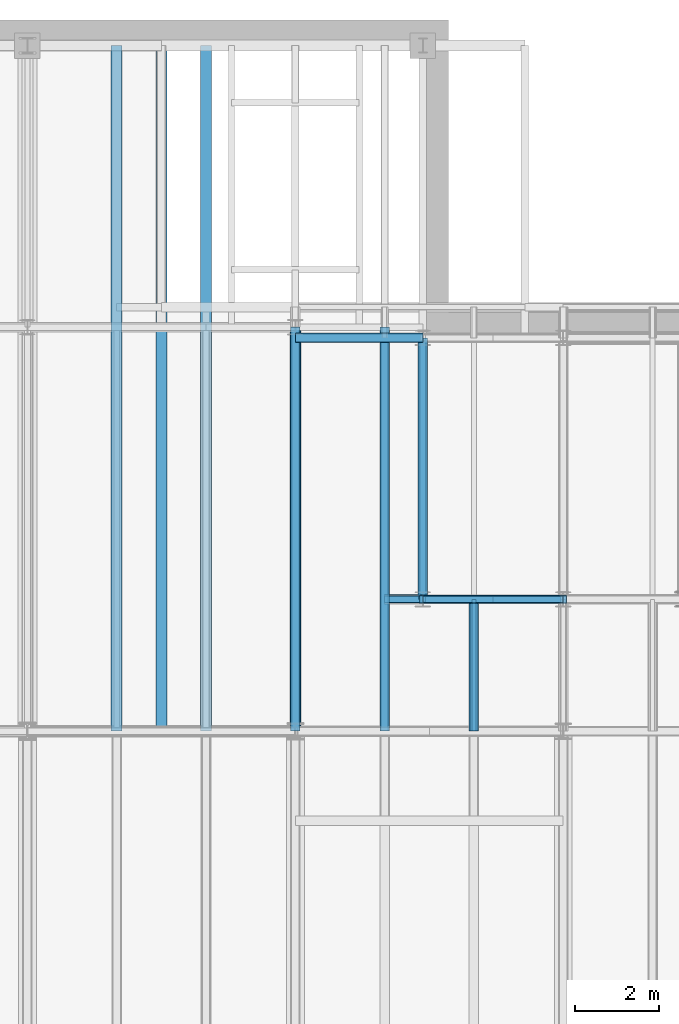
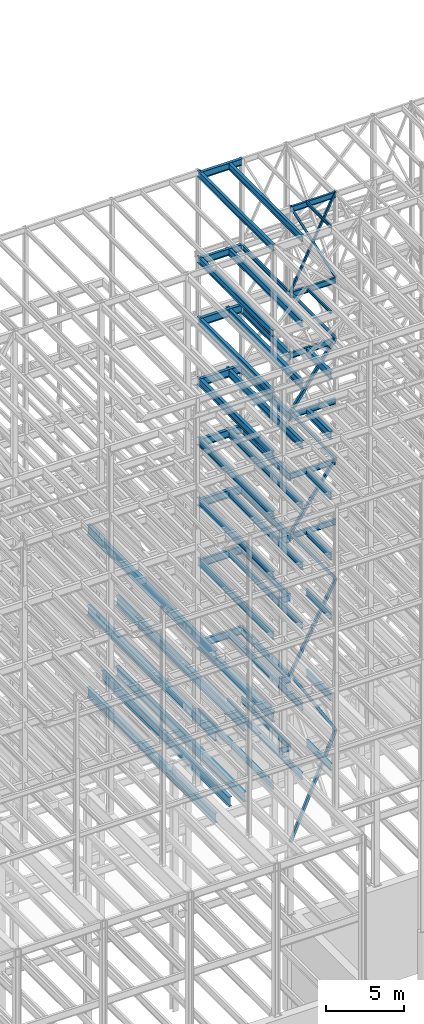
# One storey, part 133 of 150: 69 beams.
"""IFC2X3 building model written with IfcOpenShell, lengths in millimetres."""

from ifc_helpers import new_model, si_unit, frame, origin_with_axes, origin_2d_with_axis, place, context, subcontext, project, spatial, hollow_rectangle, i_section, extrude, material, type_object, element, save


model = new_model("IFC2X3")

# Units and contexts
model_context = context("Model", 3, precision=1e-05, world=origin_with_axes())
body_context = subcontext(model_context, "Body", "Model", "MODEL_VIEW")
ifc_project = project(units=[si_unit("LENGTHUNIT", "METRE", prefix="MILLI"), si_unit("AREAUNIT", "SQUARE_METRE"), si_unit("VOLUMEUNIT", "CUBIC_METRE"), si_unit("MASSUNIT", "GRAM", prefix="KILO"), si_unit("TIMEUNIT", "SECOND"), si_unit("PLANEANGLEUNIT", "RADIAN"), si_unit("SOLIDANGLEUNIT", "STERADIAN"), si_unit("THERMODYNAMICTEMPERATUREUNIT", "DEGREE_CELSIUS"), si_unit("LUMINOUSINTENSITYUNIT", "LUMEN")], contexts=[model_context])

# Site, building, storey
site_placement = place(None, origin_with_axes())
site = spatial("IfcSite", under=ifc_project, at=site_placement, CompositionType="ELEMENT")
building_placement = place(site_placement, origin_with_axes())
building = spatial("IfcBuilding", under=site, at=building_placement, Name="Undefined", CompositionType="ELEMENT")
storey_placement = place(building_placement, origin_with_axes())
storey = spatial("IfcBuildingStorey", under=building, at=storey_placement, Name="Undefined", CompositionType="ELEMENT", Elevation=0.0)

# Beams
ifc_material_1 = material()
beam_type_1 = type_object("IfcBeamType", Name="HSS8X8X3/8", PredefinedType="NOTDEFINED")
beam_1_placement = place(storey_placement, frame((56591.2, 25628.6, 54483.0), z_axis=(0.815507132555285, 0.0, 0.578747023103753), x_axis=(-0.578747023103752, 0.0, 0.815507132555286)))
element("IfcBeam", 1, at=beam_1_placement, inside=storey, type_object=beam_type_1, material=ifc_material_1, Name="BEAM", ObjectType="HSS8X8X3/8", context=body_context, shape_type="SweptSolid", body=[
    extrude(hollow_rectangle(XDim=203.2, YDim=203.2, WallThickness=9.525, InnerFilletRadius=9.5249, OuterFilletRadius=19.0499, at=origin_2d_with_axis()), frame((5793.20491610646, 0.0, -3.21587474211652e-13), z_axis=(-1.0, 0.0, 0.0), x_axis=(0.0, -1.0, 0.0)), (0.0, 0.0, 1.0), 5793.20491610646),
])
beam_2_placement = place(storey_placement, frame((53238.4000344438, 25628.6, 49758.5997408036), z_axis=(-0.815507179752522, 0.0, 0.578746956598553), x_axis=(0.578746956598556, 0.0, 0.81550717975252)))
element("IfcBeam", 2, at=beam_2_placement, inside=storey, type_object=beam_type_1, material=ifc_material_1, Name="BEAM", ObjectType="HSS8X8X3/8", context=body_context, shape_type="SweptSolid", body=[
    extrude(hollow_rectangle(XDim=203.2, YDim=203.2, WallThickness=9.525, InnerFilletRadius=9.5249, OuterFilletRadius=19.0499, at=origin_2d_with_axis()), frame((5793.20510754876, 0.0, 0.0), z_axis=(-1.0, 0.0, 0.0), x_axis=(0.0, -1.0, 0.0)), (0.0, 0.0, 1.0), 5793.20510754876),
])
beam_3_placement = place(storey_placement, frame((56591.2, 25628.6, 45034.2), z_axis=(0.815507132555285, 0.0, 0.578747023103753), x_axis=(-0.578747023103752, 0.0, 0.815507132555286)))
element("IfcBeam", 3, at=beam_3_placement, inside=storey, type_object=beam_type_1, material=ifc_material_1, Name="BEAM", ObjectType="HSS8X8X3/8", context=body_context, shape_type="SweptSolid", body=[
    extrude(hollow_rectangle(XDim=203.2, YDim=203.2, WallThickness=9.525, InnerFilletRadius=9.5249, OuterFilletRadius=19.0499, at=origin_2d_with_axis()), frame((5793.20491610646, 0.0, -3.21587474211652e-13), z_axis=(-1.0, 0.0, 0.0), x_axis=(0.0, -1.0, 0.0)), (0.0, 0.0, 1.0), 5793.20491610647),
])
for number, where, z_axis, x_axis, name in (
    (4, (53238.4, 25628.6, 40309.8), (-0.815507179752522, 0.0, 0.578746956598553), (0.578746956598556, 0.0, 0.81550717975252), "BEAM"),
    (5, (56591.2, 25628.6, 35585.4), (0.815507132555285, 0.0, 0.578747023103753), (-0.578747023103752, 0.0, 0.815507132555286), "BEAM"),
):
    element("IfcBeam", number, at=place(storey_placement, frame(where, z_axis=z_axis, x_axis=x_axis)), inside=storey, type_object=beam_type_1, material=ifc_material_1, Name=name, ObjectType="HSS8X8X3/8", context=body_context, shape_type="SweptSolid", body=[
        extrude(hollow_rectangle(XDim=203.2, YDim=203.2, WallThickness=9.525, InnerFilletRadius=9.5249, OuterFilletRadius=19.0499, at=origin_2d_with_axis()), frame((5793.20491610646, 0.0, -3.21587474211652e-13), z_axis=(-1.0, 0.0, 0.0), x_axis=(0.0, -1.0, 0.0)), (0.0, 0.0, 1.0), 5793.20491610646),
    ])
beam_4_placement = place(storey_placement, frame((53238.4001450863, 25628.6, 29286.1995317612), z_axis=(-0.882746779817135, 0.0, 0.469849042483306), x_axis=(0.469849042483308, 0.0, 0.882746779817133)))
element("IfcBeam", 6, at=beam_4_placement, inside=storey, type_object=beam_type_1, material=ifc_material_1, Name="BEAM", ObjectType="HSS8X8X3/8", context=body_context, shape_type="SweptSolid", body=[
    extrude(hollow_rectangle(XDim=203.2, YDim=203.2, WallThickness=9.525, InnerFilletRadius=9.5249, OuterFilletRadius=19.0499, at=origin_2d_with_axis()), frame((7135.90873022981, 0.0, -3.9612250869624e-13), z_axis=(-1.0, 0.0, 0.0), x_axis=(0.0, -1.0, 0.0)), (0.0, 0.0, 1.0), 7135.90873022981),
])
beam_5_placement = place(storey_placement, frame((56591.2, 25628.6, 23774.4), z_axis=(0.854350562966211, 0.0, 0.519697138302029), x_axis=(-0.519697138302028, 0.0, 0.854350562966211)))
element("IfcBeam", 7, at=beam_5_placement, inside=storey, type_object=beam_type_1, material=ifc_material_1, Name="BEAM", ObjectType="HSS8X8X3/8", context=body_context, shape_type="SweptSolid", body=[
    extrude(hollow_rectangle(XDim=203.2, YDim=203.2, WallThickness=9.525, InnerFilletRadius=9.5249, OuterFilletRadius=19.0499, at=origin_2d_with_axis()), frame((6451.44999825621, 0.0, 0.0), z_axis=(-1.0, 0.0, 0.0), x_axis=(0.0, -1.0, 0.0)), (0.0, 0.0, 1.0), 6451.44999825621),
])
beam_6_placement = place(storey_placement, frame((53238.4, 25628.6, 16154.4), z_axis=(-0.915315032422766, 0.0, 0.402738614266017), x_axis=(0.402738614266017, 0.0, 0.915315032422766)))
element("IfcBeam", 8, at=beam_6_placement, inside=storey, type_object=beam_type_1, material=ifc_material_1, Name="BEAM", ObjectType="HSS8X8X3/8", context=body_context, shape_type="SweptSolid", body=[
    extrude(hollow_rectangle(XDim=203.2, YDim=203.2, WallThickness=9.525, InnerFilletRadius=9.5249, OuterFilletRadius=19.0499, at=origin_2d_with_axis()), frame((8325.00257297258, -7.27595761418343e-12, -4.62130476828891e-13), z_axis=(-1.0, 0.0, 0.0), x_axis=(0.0, -1.0, 0.0)), (0.0, 0.0, 1.0), 8325.00257297258),
])
ifc_material_2 = material(Name="STEEL/A992")
beam_type_2 = type_object("IfcBeamType", Name="W18X35", PredefinedType="NOTDEFINED")
for number, where, z_axis, x_axis, name in (
    (9, (53238.4, 25628.6, 65687.575), (0.0, 0.0, 1.0), (1.0, 0.0, 0.0), "BEAM"),
    (10, (53238.4, 25628.6, 58981.975), (0.0, 0.0, 1.0), (1.0, 0.0, 0.0), "BEAM"),
    (11, (53238.4, 25628.6, 54257.575), (0.0, 0.0, 1.0), (1.0, 0.0, 0.0), "BEAM"),
    (12, (53238.4, 25628.6, 49533.175), (0.0, 0.0, 1.0), (1.0, 0.0, 0.0), "BEAM"),
    (13, (53238.4, 25628.6, 44808.775), (0.0, 0.0, 1.0), (1.0, 0.0, 0.0), "BEAM"),
    (14, (53238.4, 25628.6, 40084.375), (0.0, 0.0, 1.0), (1.0, 0.0, 0.0), "BEAM"),
):
    element("IfcBeam", number, at=place(storey_placement, frame(where, z_axis=z_axis, x_axis=x_axis)), inside=storey, type_object=beam_type_2, material=ifc_material_2, Name=name, ObjectType="W18X35", context=body_context, shape_type="SweptSolid", body=[
        extrude(i_section(OverallWidth=152.4, OverallDepth=450.85, WebThickness=7.9375, FlangeThickness=10.795, FilletRadius=17.78, at=origin_2d_with_axis()), frame((3352.8, 0.0, 0.0), z_axis=(-1.0, 0.0, 0.0), x_axis=(0.0, -1.0, 0.0)), (0.0, 0.0, 1.0), 3352.8),
    ])
beam_7_placement = place(storey_placement, frame((53238.4, 25628.6, 23548.975), z_axis=(0.0, 0.0, 1.0), x_axis=(0.0, 1.0, 0.0)))
element("IfcBeam", 15, at=beam_7_placement, inside=storey, type_object=beam_type_2, material=ifc_material_2, Name="BEAM", ObjectType="W18X35", context=body_context, shape_type="SweptSolid", body=[
    extrude(i_section(OverallWidth=152.4, OverallDepth=450.85, WebThickness=7.9375, FlangeThickness=10.795, FilletRadius=17.78, at=origin_2d_with_axis()), frame((6248.40000000001, 0.0, 0.0), z_axis=(-1.0, 0.0, 0.0), x_axis=(0.0, -1.0, 0.0)), (0.0, 0.0, 1.0), 6248.40000000001),
])
beam_8_placement = place(storey_placement, frame((52324.0, 25628.6, 23548.975), z_axis=(0.0, 0.0, 1.0), x_axis=(1.0, 0.0, 0.0)))
element("IfcBeam", 16, at=beam_8_placement, inside=storey, type_object=beam_type_2, material=ifc_material_2, Name="BEAM", ObjectType="W18X35", context=body_context, shape_type="SweptSolid", body=[
    extrude(i_section(OverallWidth=152.4, OverallDepth=450.85, WebThickness=7.9375, FlangeThickness=10.795, FilletRadius=17.78, at=origin_2d_with_axis()), frame((914.400000000009, 0.0, 0.0), z_axis=(-1.0, 0.0, 0.0), x_axis=(0.0, -1.0, 0.0)), (0.0, 0.0, 1.0), 914.400000000001),
])
beam_type_3 = type_object("IfcBeamType", Name="HSS6X6X1/4", PredefinedType="NOTDEFINED")
for number, where, z_axis, x_axis, name in (
    (17, (56591.2, 25628.6, 59207.4), (0.894427210999918, 0.0, 0.447213555499951), (-0.447213555499953, 0.0, 0.894427210999917), "BEAM"),
    (18, (53238.4, 25628.6, 59207.4), (-0.894427210999918, 0.0, 0.447213555499951), (0.447213555499953, 0.0, 0.894427210999917), "BEAM"),
):
    element("IfcBeam", number, at=place(storey_placement, frame(where, z_axis=z_axis, x_axis=x_axis)), inside=storey, type_object=beam_type_3, material=ifc_material_1, Name=name, ObjectType="HSS6X6X1/4", context=body_context, shape_type="SweptSolid", body=[
        extrude(hollow_rectangle(XDim=152.4, YDim=152.4, WallThickness=6.35, InnerFilletRadius=6.3499, OuterFilletRadius=12.6999, at=origin_2d_with_axis()), frame((7497.08871496129, 0.0, 0.0), z_axis=(-1.0, 0.0, 0.0), x_axis=(0.0, -1.0, 0.0)), (0.0, 0.0, 1.0), 7497.08871496129),
    ])
beam_type_4 = type_object("IfcBeamType", Name="W24X68", PredefinedType="NOTDEFINED")
beam_9_placement = place(storey_placement, frame((53238.4, 25628.6, 54181.375), z_axis=(0.0, 0.0, 1.0), x_axis=(0.0, 1.0, 0.0)))
element("IfcBeam", 19, at=beam_9_placement, inside=storey, type_object=beam_type_4, material=ifc_material_2, Name="BEAM", ObjectType="W24X68", context=body_context, shape_type="SweptSolid", body=[
    extrude(i_section(OverallWidth=227.838, OverallDepth=603.25, WebThickness=11.1125, FlangeThickness=14.859, FilletRadius=23.2409, at=origin_2d_with_axis()), frame((6248.40000000001, 0.0, 0.0), z_axis=(-1.0, 0.0, 0.0), x_axis=(0.0, -1.0, 0.0)), (0.0, 0.0, 1.0), 6248.40000000001),
])
for number, where, z_axis, x_axis, name in (
    (20, (52324.0, 22479.0, 54181.375), (0.0, 0.0, 1.0), (0.0, 1.0, 0.0), "BEAM"),
    (21, (50190.4, 22479.0, 54181.375), (0.0, 0.0, 1.0), (0.0, 1.0, 0.0), "BEAM"),
):
    element("IfcBeam", number, at=place(storey_placement, frame(where, z_axis=z_axis, x_axis=x_axis)), inside=storey, type_object=beam_type_4, material=ifc_material_2, Name=name, ObjectType="W24X68", context=body_context, shape_type="SweptSolid", body=[
        extrude(i_section(OverallWidth=227.838, OverallDepth=603.25, WebThickness=11.1125, FlangeThickness=14.859, FilletRadius=23.2409, at=origin_2d_with_axis()), frame((9652.0, 0.0, 0.0), z_axis=(-1.0, 0.0, 0.0), x_axis=(0.0, -1.0, 0.0)), (0.0, 0.0, 1.0), 9652.0),
    ])
beam_10_placement = place(storey_placement, frame((50190.4, 31877.0, 54181.375), z_axis=(0.0, 0.0, 1.0), x_axis=(1.0, 0.0, 0.0)))
element("IfcBeam", 22, at=beam_10_placement, inside=storey, type_object=beam_type_4, material=ifc_material_2, Name="BEAM", ObjectType="W24X68", context=body_context, shape_type="SweptSolid", body=[
    extrude(i_section(OverallWidth=227.838, OverallDepth=603.25, WebThickness=11.1125, FlangeThickness=14.859, FilletRadius=23.2409, at=origin_2d_with_axis()), frame((3048.0, 0.0, 0.0), z_axis=(-1.0, 0.0, 0.0), x_axis=(0.0, -1.0, 0.0)), (0.0, 0.0, 1.0), 3047.99999999999),
])
beam_11_placement = place(storey_placement, frame((54457.6, 22479.0, 54181.375), z_axis=(0.0, 0.0, 1.0), x_axis=(0.0, 1.0, 0.0)))
element("IfcBeam", 23, at=beam_11_placement, inside=storey, type_object=beam_type_4, material=ifc_material_2, Name="BEAM", ObjectType="W24X68", context=body_context, shape_type="SweptSolid", body=[
    extrude(i_section(OverallWidth=227.838, OverallDepth=603.25, WebThickness=11.1125, FlangeThickness=14.859, FilletRadius=23.2409, at=origin_2d_with_axis()), frame((3149.59999999999, 0.0, 0.0), z_axis=(-1.0, 0.0, 0.0), x_axis=(0.0, -1.0, 0.0)), (0.0, 0.0, 1.0), 3149.6),
])
beam_12_placement = place(storey_placement, frame((53238.4, 25628.6, 49456.975), z_axis=(0.0, 0.0, 1.0), x_axis=(0.0, 1.0, 0.0)))
element("IfcBeam", 24, at=beam_12_placement, inside=storey, type_object=beam_type_4, material=ifc_material_2, Name="BEAM", ObjectType="W24X68", context=body_context, shape_type="SweptSolid", body=[
    extrude(i_section(OverallWidth=227.838, OverallDepth=603.25, WebThickness=11.1125, FlangeThickness=14.859, FilletRadius=23.2409, at=origin_2d_with_axis()), frame((6248.40000000001, 0.0, 0.0), z_axis=(-1.0, 0.0, 0.0), x_axis=(0.0, -1.0, 0.0)), (0.0, 0.0, 1.0), 6248.40000000001),
])
for number, where, z_axis, x_axis, name in (
    (25, (52324.0, 22479.0, 49456.975), (0.0, 0.0, 1.0), (0.0, 1.0, 0.0), "BEAM"),
    (26, (50190.4, 22479.0, 49456.975), (0.0, 0.0, 1.0), (0.0, 1.0, 0.0), "BEAM"),
):
    element("IfcBeam", number, at=place(storey_placement, frame(where, z_axis=z_axis, x_axis=x_axis)), inside=storey, type_object=beam_type_4, material=ifc_material_2, Name=name, ObjectType="W24X68", context=body_context, shape_type="SweptSolid", body=[
        extrude(i_section(OverallWidth=227.838, OverallDepth=603.25, WebThickness=11.1125, FlangeThickness=14.859, FilletRadius=23.2409, at=origin_2d_with_axis()), frame((9652.0, 0.0, 0.0), z_axis=(-1.0, 0.0, 0.0), x_axis=(0.0, -1.0, 0.0)), (0.0, 0.0, 1.0), 9652.0),
    ])
beam_13_placement = place(storey_placement, frame((50190.4, 31877.0, 49456.975), z_axis=(0.0, 0.0, 1.0), x_axis=(1.0, 0.0, 0.0)))
element("IfcBeam", 27, at=beam_13_placement, inside=storey, type_object=beam_type_4, material=ifc_material_2, Name="BEAM", ObjectType="W24X68", context=body_context, shape_type="SweptSolid", body=[
    extrude(i_section(OverallWidth=227.838, OverallDepth=603.25, WebThickness=11.1125, FlangeThickness=14.859, FilletRadius=23.2409, at=origin_2d_with_axis()), frame((3048.0, 0.0, 0.0), z_axis=(-1.0, 0.0, 0.0), x_axis=(0.0, -1.0, 0.0)), (0.0, 0.0, 1.0), 3047.99999999999),
])
beam_14_placement = place(storey_placement, frame((54457.6, 22479.0, 49456.975), z_axis=(0.0, 0.0, 1.0), x_axis=(0.0, 1.0, 0.0)))
element("IfcBeam", 28, at=beam_14_placement, inside=storey, type_object=beam_type_4, material=ifc_material_2, Name="BEAM", ObjectType="W24X68", context=body_context, shape_type="SweptSolid", body=[
    extrude(i_section(OverallWidth=227.838, OverallDepth=603.25, WebThickness=11.1125, FlangeThickness=14.859, FilletRadius=23.2409, at=origin_2d_with_axis()), frame((3149.59999999999, 0.0, 0.0), z_axis=(-1.0, 0.0, 0.0), x_axis=(0.0, -1.0, 0.0)), (0.0, 0.0, 1.0), 3149.6),
])
beam_15_placement = place(storey_placement, frame((53238.4, 25628.6, 44732.575), z_axis=(0.0, 0.0, 1.0), x_axis=(0.0, 1.0, 0.0)))
element("IfcBeam", 29, at=beam_15_placement, inside=storey, type_object=beam_type_4, material=ifc_material_2, Name="BEAM", ObjectType="W24X68", context=body_context, shape_type="SweptSolid", body=[
    extrude(i_section(OverallWidth=227.838, OverallDepth=603.25, WebThickness=11.1125, FlangeThickness=14.859, FilletRadius=23.2409, at=origin_2d_with_axis()), frame((6248.40000000001, 0.0, 0.0), z_axis=(-1.0, 0.0, 0.0), x_axis=(0.0, -1.0, 0.0)), (0.0, 0.0, 1.0), 6248.40000000001),
])
for number, where, z_axis, x_axis, name in (
    (30, (52324.0, 22479.0, 44732.575), (0.0, 0.0, 1.0), (0.0, 1.0, 0.0), "BEAM"),
    (31, (50190.4, 22479.0, 44732.575), (0.0, 0.0, 1.0), (0.0, 1.0, 0.0), "BEAM"),
):
    element("IfcBeam", number, at=place(storey_placement, frame(where, z_axis=z_axis, x_axis=x_axis)), inside=storey, type_object=beam_type_4, material=ifc_material_2, Name=name, ObjectType="W24X68", context=body_context, shape_type="SweptSolid", body=[
        extrude(i_section(OverallWidth=227.838, OverallDepth=603.25, WebThickness=11.1125, FlangeThickness=14.859, FilletRadius=23.2409, at=origin_2d_with_axis()), frame((9652.0, 0.0, 0.0), z_axis=(-1.0, 0.0, 0.0), x_axis=(0.0, -1.0, 0.0)), (0.0, 0.0, 1.0), 9652.0),
    ])
beam_16_placement = place(storey_placement, frame((50190.4, 31877.0, 44732.575), z_axis=(0.0, 0.0, 1.0), x_axis=(1.0, 0.0, 0.0)))
element("IfcBeam", 32, at=beam_16_placement, inside=storey, type_object=beam_type_4, material=ifc_material_2, Name="BEAM", ObjectType="W24X68", context=body_context, shape_type="SweptSolid", body=[
    extrude(i_section(OverallWidth=227.838, OverallDepth=603.25, WebThickness=11.1125, FlangeThickness=14.859, FilletRadius=23.2409, at=origin_2d_with_axis()), frame((3048.0, 0.0, 0.0), z_axis=(-1.0, 0.0, 0.0), x_axis=(0.0, -1.0, 0.0)), (0.0, 0.0, 1.0), 3047.99999999999),
])
beam_17_placement = place(storey_placement, frame((54457.6, 22479.0, 44732.575), z_axis=(0.0, 0.0, 1.0), x_axis=(0.0, 1.0, 0.0)))
element("IfcBeam", 33, at=beam_17_placement, inside=storey, type_object=beam_type_4, material=ifc_material_2, Name="BEAM", ObjectType="W24X68", context=body_context, shape_type="SweptSolid", body=[
    extrude(i_section(OverallWidth=227.838, OverallDepth=603.25, WebThickness=11.1125, FlangeThickness=14.859, FilletRadius=23.2409, at=origin_2d_with_axis()), frame((3149.59999999999, 0.0, 0.0), z_axis=(-1.0, 0.0, 0.0), x_axis=(0.0, -1.0, 0.0)), (0.0, 0.0, 1.0), 3149.6),
])
beam_18_placement = place(storey_placement, frame((53238.4, 25628.6, 40008.175), z_axis=(0.0, 0.0, 1.0), x_axis=(0.0, 1.0, 0.0)))
element("IfcBeam", 34, at=beam_18_placement, inside=storey, type_object=beam_type_4, material=ifc_material_2, Name="BEAM", ObjectType="W24X68", context=body_context, shape_type="SweptSolid", body=[
    extrude(i_section(OverallWidth=227.838, OverallDepth=603.25, WebThickness=11.1125, FlangeThickness=14.859, FilletRadius=23.2409, at=origin_2d_with_axis()), frame((6248.40000000001, 0.0, 0.0), z_axis=(-1.0, 0.0, 0.0), x_axis=(0.0, -1.0, 0.0)), (0.0, 0.0, 1.0), 6248.40000000001),
])
beam_19_placement = place(storey_placement, frame((52324.0, 25628.6, 40008.175), z_axis=(0.0, 0.0, 1.0), x_axis=(1.0, 0.0, 0.0)))
element("IfcBeam", 35, at=beam_19_placement, inside=storey, type_object=beam_type_4, material=ifc_material_2, Name="BEAM", ObjectType="W24X68", context=body_context, shape_type="SweptSolid", body=[
    extrude(i_section(OverallWidth=227.838, OverallDepth=603.25, WebThickness=11.1125, FlangeThickness=14.859, FilletRadius=23.2409, at=origin_2d_with_axis()), frame((914.400000000009, 0.0, 0.0), z_axis=(-1.0, 0.0, 0.0), x_axis=(0.0, -1.0, 0.0)), (0.0, 0.0, 1.0), 914.400000000001),
])
for number, where, z_axis, x_axis, name in (
    (36, (52324.0, 22479.0, 40008.175), (0.0, 0.0, 1.0), (0.0, 1.0, 0.0), "BEAM"),
    (37, (50190.4, 22479.0, 40008.175), (0.0, 0.0, 1.0), (0.0, 1.0, 0.0), "BEAM"),
):
    element("IfcBeam", number, at=place(storey_placement, frame(where, z_axis=z_axis, x_axis=x_axis)), inside=storey, type_object=beam_type_4, material=ifc_material_2, Name=name, ObjectType="W24X68", context=body_context, shape_type="SweptSolid", body=[
        extrude(i_section(OverallWidth=227.838, OverallDepth=603.25, WebThickness=11.1125, FlangeThickness=14.859, FilletRadius=23.2409, at=origin_2d_with_axis()), frame((9652.0, 0.0, 0.0), z_axis=(-1.0, 0.0, 0.0), x_axis=(0.0, -1.0, 0.0)), (0.0, 0.0, 1.0), 9652.0),
    ])
beam_20_placement = place(storey_placement, frame((50190.4, 31877.0, 40008.175), z_axis=(0.0, 0.0, 1.0), x_axis=(1.0, 0.0, 0.0)))
element("IfcBeam", 38, at=beam_20_placement, inside=storey, type_object=beam_type_4, material=ifc_material_2, Name="BEAM", ObjectType="W24X68", context=body_context, shape_type="SweptSolid", body=[
    extrude(i_section(OverallWidth=227.838, OverallDepth=603.25, WebThickness=11.1125, FlangeThickness=14.859, FilletRadius=23.2409, at=origin_2d_with_axis()), frame((3048.0, 0.0, 0.0), z_axis=(-1.0, 0.0, 0.0), x_axis=(0.0, -1.0, 0.0)), (0.0, 0.0, 1.0), 3047.99999999999),
])
beam_21_placement = place(storey_placement, frame((54457.6, 22479.0, 40008.175), z_axis=(0.0, 0.0, 1.0), x_axis=(0.0, 1.0, 0.0)))
element("IfcBeam", 39, at=beam_21_placement, inside=storey, type_object=beam_type_4, material=ifc_material_2, Name="BEAM", ObjectType="W24X68", context=body_context, shape_type="SweptSolid", body=[
    extrude(i_section(OverallWidth=227.838, OverallDepth=603.25, WebThickness=11.1125, FlangeThickness=14.859, FilletRadius=23.2409, at=origin_2d_with_axis()), frame((3149.59999999999, 0.0, 0.0), z_axis=(-1.0, 0.0, 0.0), x_axis=(0.0, -1.0, 0.0)), (0.0, 0.0, 1.0), 3149.6),
])
beam_type_5 = type_object("IfcBeamType", Name="W14X22", PredefinedType="NOTDEFINED")
beam_22_placement = place(storey_placement, frame((53238.4, 25628.6, 59032.775), z_axis=(0.0, 0.0, 1.0), x_axis=(0.0, 1.0, 0.0)))
element("IfcBeam", 40, at=beam_22_placement, inside=storey, type_object=beam_type_5, material=ifc_material_2, Name="BEAM", ObjectType="W14X22", context=body_context, shape_type="SweptSolid", body=[
    extrude(i_section(OverallWidth=127.0, OverallDepth=349.25, WebThickness=6.3499, FlangeThickness=8.509, FilletRadius=18.4785, at=origin_2d_with_axis()), frame((6248.40000000001, 0.0, 0.0), z_axis=(-1.0, 0.0, 0.0), x_axis=(0.0, -1.0, 0.0)), (0.0, 0.0, 1.0), 6248.40000000001),
])
beam_type_6 = type_object("IfcBeamType", Name="W21X55", PredefinedType="NOTDEFINED")
beam_23_placement = place(storey_placement, frame((52324.0, 22479.0, 65649.475), z_axis=(0.0, 0.0, 1.0), x_axis=(0.0, 1.0, 0.0)))
element("IfcBeam", 41, at=beam_23_placement, inside=storey, type_object=beam_type_6, material=ifc_material_2, Name="BEAM", ObjectType="W21X55", context=body_context, shape_type="SweptSolid", body=[
    extrude(i_section(OverallWidth=208.788, OverallDepth=527.05, WebThickness=9.5, FlangeThickness=13.2588, FilletRadius=16.8624, at=origin_2d_with_axis()), frame((9398.0, 0.0, 0.0), z_axis=(-1.0, 0.0, 0.0), x_axis=(0.0, -1.0, 0.0)), (0.0, 0.0, 1.0), 9398.0),
])
beam_24_placement = place(storey_placement, frame((50190.4, 31877.0, 65649.475), z_axis=(0.0, 0.0, 1.0), x_axis=(1.0, 0.0, 0.0)))
element("IfcBeam", 42, at=beam_24_placement, inside=storey, type_object=beam_type_6, material=ifc_material_2, Name="BEAM", ObjectType="W21X55", context=body_context, shape_type="SweptSolid", body=[
    extrude(i_section(OverallWidth=208.788, OverallDepth=527.05, WebThickness=9.5, FlangeThickness=13.2588, FilletRadius=16.8624, at=origin_2d_with_axis()), frame((3048.0, 0.0, 0.0), z_axis=(-1.0, 0.0, 0.0), x_axis=(0.0, -1.0, 0.0)), (0.0, 0.0, 1.0), 3048.0),
])
beam_25_placement = place(storey_placement, frame((50190.4, 22479.0, 65649.475), z_axis=(0.0, 0.0, 1.0), x_axis=(0.0, 1.0, 0.0)))
element("IfcBeam", 43, at=beam_25_placement, inside=storey, type_object=beam_type_6, material=ifc_material_2, Name="BEAM", ObjectType="W21X55", context=body_context, shape_type="SweptSolid", body=[
    extrude(i_section(OverallWidth=208.788, OverallDepth=527.05, WebThickness=9.5, FlangeThickness=13.2588, FilletRadius=16.8624, at=origin_2d_with_axis()), frame((9652.0, 0.0, 0.0), z_axis=(-1.0, 0.0, 0.0), x_axis=(0.0, -1.0, 0.0)), (0.0, 0.0, 1.0), 9652.0),
])
beam_26_placement = place(storey_placement, frame((52324.0, 22479.0, 58943.875), z_axis=(0.0, 0.0, 1.0), x_axis=(0.0, 1.0, 0.0)))
element("IfcBeam", 44, at=beam_26_placement, inside=storey, type_object=beam_type_6, material=ifc_material_2, Name="BEAM", ObjectType="W21X55", context=body_context, shape_type="SweptSolid", body=[
    extrude(i_section(OverallWidth=208.788, OverallDepth=527.05, WebThickness=9.5, FlangeThickness=13.2588, FilletRadius=16.8624, at=origin_2d_with_axis()), frame((9398.0, 0.0, 0.0), z_axis=(-1.0, 0.0, 0.0), x_axis=(0.0, -1.0, 0.0)), (0.0, 0.0, 1.0), 9398.0),
])
beam_27_placement = place(storey_placement, frame((50190.4, 31877.0, 58943.875), z_axis=(0.0, 0.0, 1.0), x_axis=(1.0, 0.0, 0.0)))
element("IfcBeam", 45, at=beam_27_placement, inside=storey, type_object=beam_type_6, material=ifc_material_2, Name="BEAM", ObjectType="W21X55", context=body_context, shape_type="SweptSolid", body=[
    extrude(i_section(OverallWidth=208.788, OverallDepth=527.05, WebThickness=9.5, FlangeThickness=13.2588, FilletRadius=16.8624, at=origin_2d_with_axis()), frame((3048.0, 0.0, 0.0), z_axis=(-1.0, 0.0, 0.0), x_axis=(0.0, -1.0, 0.0)), (0.0, 0.0, 1.0), 3048.0),
])
beam_28_placement = place(storey_placement, frame((50190.4, 22479.0, 58943.875), z_axis=(0.0, 0.0, 1.0), x_axis=(0.0, 1.0, 0.0)))
element("IfcBeam", 46, at=beam_28_placement, inside=storey, type_object=beam_type_6, material=ifc_material_2, Name="BEAM", ObjectType="W21X55", context=body_context, shape_type="SweptSolid", body=[
    extrude(i_section(OverallWidth=208.788, OverallDepth=527.05, WebThickness=9.5, FlangeThickness=13.2588, FilletRadius=16.8624, at=origin_2d_with_axis()), frame((9652.0, 0.0, 0.0), z_axis=(-1.0, 0.0, 0.0), x_axis=(0.0, -1.0, 0.0)), (0.0, 0.0, 1.0), 9652.0),
])
beam_type_7 = type_object("IfcBeamType", Name="W10X15", PredefinedType="NOTDEFINED")
for number, where, z_axis, x_axis, name in (
    (47, (54457.6, 22479.0, 65786.0), (0.0, 0.0, 1.0), (0.0, 1.0, 0.0), "BEAM"),
    (48, (54457.6, 22479.0, 59080.4), (0.0, 0.0, 1.0), (0.0, 1.0, 0.0), "BEAM"),
):
    element("IfcBeam", number, at=place(storey_placement, frame(where, z_axis=z_axis, x_axis=x_axis)), inside=storey, type_object=beam_type_7, material=ifc_material_2, Name=name, ObjectType="W10X15", context=body_context, shape_type="SweptSolid", body=[
        extrude(i_section(OverallWidth=101.6, OverallDepth=254.0, WebThickness=6.3499, FlangeThickness=6.858, FilletRadius=13.7795, at=origin_2d_with_axis()), frame((3149.59999999999, 0.0, 0.0), z_axis=(-1.0, 0.0, 0.0), x_axis=(0.0, -1.0, 0.0)), (0.0, 0.0, 1.0), 3149.6),
    ])
beam_type_8 = type_object("IfcBeamType", Name="W24X55", PredefinedType="NOTDEFINED")
beam_29_placement = place(storey_placement, frame((54457.6, 22479.0, 28986.1625), z_axis=(0.0, 0.0, 1.0), x_axis=(0.0, 1.0, 0.0)))
element("IfcBeam", 49, at=beam_29_placement, inside=storey, type_object=beam_type_8, material=ifc_material_2, Name="BEAM", ObjectType="W24X55", context=body_context, shape_type="SweptSolid", body=[
    extrude(i_section(OverallWidth=178.054, OverallDepth=600.075, WebThickness=9.5249, FlangeThickness=12.827, FilletRadius=23.6854, at=origin_2d_with_axis()), frame((3149.59999999999, 0.0, 0.0), z_axis=(-1.0, 0.0, 0.0), x_axis=(0.0, -1.0, 0.0)), (0.0, 0.0, 1.0), 3149.6),
])
beam_30_placement = place(storey_placement, frame((53238.4, 25628.6, 28986.1625), z_axis=(0.0, 0.0, 1.0), x_axis=(0.0, 1.0, 0.0)))
element("IfcBeam", 50, at=beam_30_placement, inside=storey, type_object=beam_type_8, material=ifc_material_2, Name="BEAM", ObjectType="W24X55", context=body_context, shape_type="SweptSolid", body=[
    extrude(i_section(OverallWidth=178.054, OverallDepth=600.075, WebThickness=9.5249, FlangeThickness=12.827, FilletRadius=23.6854, at=origin_2d_with_axis()), frame((6248.40000000001, 0.0, 0.0), z_axis=(-1.0, 0.0, 0.0), x_axis=(0.0, -1.0, 0.0)), (0.0, 0.0, 1.0), 6248.40000000001),
])
beam_31_placement = place(storey_placement, frame((52324.0, 25628.6, 28986.1625), z_axis=(0.0, 0.0, 1.0), x_axis=(1.0, 0.0, 0.0)))
element("IfcBeam", 51, at=beam_31_placement, inside=storey, type_object=beam_type_8, material=ifc_material_2, Name="BEAM", ObjectType="W24X55", context=body_context, shape_type="SweptSolid", body=[
    extrude(i_section(OverallWidth=178.054, OverallDepth=600.075, WebThickness=9.5249, FlangeThickness=12.827, FilletRadius=23.6854, at=origin_2d_with_axis()), frame((914.400000000009, 0.0, 0.0), z_axis=(-1.0, 0.0, 0.0), x_axis=(0.0, -1.0, 0.0)), (0.0, 0.0, 1.0), 914.400000000001),
])
beam_32_placement = place(storey_placement, frame((52324.0, 22479.0, 28986.1625), z_axis=(0.0, 0.0, 1.0), x_axis=(0.0, 1.0, 0.0)))
element("IfcBeam", 52, at=beam_32_placement, inside=storey, type_object=beam_type_8, material=ifc_material_2, Name="BEAM", ObjectType="W24X55", context=body_context, shape_type="SweptSolid", body=[
    extrude(i_section(OverallWidth=178.054, OverallDepth=600.075, WebThickness=9.5249, FlangeThickness=12.827, FilletRadius=23.6854, at=origin_2d_with_axis()), frame((9398.0, 0.0, 0.0), z_axis=(-1.0, 0.0, 0.0), x_axis=(0.0, -1.0, 0.0)), (0.0, 0.0, 1.0), 9398.0),
])
beam_33_placement = place(storey_placement, frame((50190.4, 31877.0, 28986.1625), z_axis=(0.0, 0.0, 1.0), x_axis=(1.0, 0.0, 0.0)))
element("IfcBeam", 53, at=beam_33_placement, inside=storey, type_object=beam_type_8, material=ifc_material_2, Name="BEAM", ObjectType="W24X55", context=body_context, shape_type="SweptSolid", body=[
    extrude(i_section(OverallWidth=178.054, OverallDepth=600.075, WebThickness=9.5249, FlangeThickness=12.827, FilletRadius=23.6854, at=origin_2d_with_axis()), frame((3048.0, 0.0, 0.0), z_axis=(-1.0, 0.0, 0.0), x_axis=(0.0, -1.0, 0.0)), (0.0, 0.0, 1.0), 3048.0),
])
beam_type_9 = type_object("IfcBeamType", Name="W21X44", PredefinedType="NOTDEFINED")
beam_34_placement = place(storey_placement, frame((53238.4, 25628.6, 35323.4625), z_axis=(0.0, 0.0, 1.0), x_axis=(0.0, 1.0, 0.0)))
element("IfcBeam", 54, at=beam_34_placement, inside=storey, type_object=beam_type_9, material=ifc_material_2, Name="BEAM", ObjectType="W21X44", context=body_context, shape_type="SweptSolid", body=[
    extrude(i_section(OverallWidth=165.1, OverallDepth=523.875, WebThickness=9.5249, FlangeThickness=11.43, FilletRadius=17.145, at=origin_2d_with_axis()), frame((6248.40000000001, 0.0, 0.0), z_axis=(-1.0, 0.0, 0.0), x_axis=(0.0, -1.0, 0.0)), (0.0, 0.0, 1.0), 6248.40000000001),
])
beam_35_placement = place(storey_placement, frame((52324.0, 25628.6, 35323.4625), z_axis=(0.0, 0.0, 1.0), x_axis=(1.0, 0.0, 0.0)))
element("IfcBeam", 55, at=beam_35_placement, inside=storey, type_object=beam_type_9, material=ifc_material_2, Name="BEAM", ObjectType="W21X44", context=body_context, shape_type="SweptSolid", body=[
    extrude(i_section(OverallWidth=165.1, OverallDepth=523.875, WebThickness=9.5249, FlangeThickness=11.43, FilletRadius=17.145, at=origin_2d_with_axis()), frame((914.400000000009, 0.0, 0.0), z_axis=(-1.0, 0.0, 0.0), x_axis=(0.0, -1.0, 0.0)), (0.0, 0.0, 1.0), 914.400000000009),
])
beam_36_placement = place(storey_placement, frame((52324.0, 22479.0, 35323.4625), z_axis=(0.0, 0.0, 1.0), x_axis=(0.0, 1.0, 0.0)))
element("IfcBeam", 56, at=beam_36_placement, inside=storey, type_object=beam_type_9, material=ifc_material_2, Name="BEAM", ObjectType="W21X44", context=body_context, shape_type="SweptSolid", body=[
    extrude(i_section(OverallWidth=165.1, OverallDepth=523.875, WebThickness=9.5249, FlangeThickness=11.43, FilletRadius=17.145, at=origin_2d_with_axis()), frame((9398.0, 0.0, 0.0), z_axis=(-1.0, 0.0, 0.0), x_axis=(0.0, -1.0, 0.0)), (0.0, 0.0, 1.0), 9398.0),
])
beam_37_placement = place(storey_placement, frame((54457.6, 22479.0, 35323.4625), z_axis=(0.0, 0.0, 1.0), x_axis=(0.0, 1.0, 0.0)))
element("IfcBeam", 57, at=beam_37_placement, inside=storey, type_object=beam_type_9, material=ifc_material_2, Name="BEAM", ObjectType="W21X44", context=body_context, shape_type="SweptSolid", body=[
    extrude(i_section(OverallWidth=165.1, OverallDepth=523.875, WebThickness=9.5249, FlangeThickness=11.43, FilletRadius=17.145, at=origin_2d_with_axis()), frame((3149.59999999999, 0.0, 0.0), z_axis=(-1.0, 0.0, 0.0), x_axis=(0.0, -1.0, 0.0)), (0.0, 0.0, 1.0), 3149.59999999999),
])
beam_38_placement = place(storey_placement, frame((54457.6, 22479.0, 23512.4625), z_axis=(0.0, 0.0, 1.0), x_axis=(0.0, 1.0, 0.0)))
element("IfcBeam", 58, at=beam_38_placement, inside=storey, type_object=beam_type_9, material=ifc_material_2, Name="BEAM", ObjectType="W21X44", context=body_context, shape_type="SweptSolid", body=[
    extrude(i_section(OverallWidth=165.1, OverallDepth=523.875, WebThickness=9.5249, FlangeThickness=11.43, FilletRadius=17.145, at=origin_2d_with_axis()), frame((3149.59999999999, 0.0, 0.0), z_axis=(-1.0, 0.0, 0.0), x_axis=(0.0, -1.0, 0.0)), (0.0, 0.0, 1.0), 3149.6),
])
for number, where, z_axis, x_axis, name in (
    (59, (52324.0, 22479.0, 23512.4625), (0.0, 0.0, 1.0), (0.0, 1.0, 0.0), "BEAM"),
    (60, (50190.4, 22479.0, 23512.4625), (0.0, 0.0, 1.0), (0.0, 1.0, 0.0), "BEAM"),
):
    element("IfcBeam", number, at=place(storey_placement, frame(where, z_axis=z_axis, x_axis=x_axis)), inside=storey, type_object=beam_type_9, material=ifc_material_2, Name=name, ObjectType="W21X44", context=body_context, shape_type="SweptSolid", body=[
        extrude(i_section(OverallWidth=165.1, OverallDepth=523.875, WebThickness=9.5249, FlangeThickness=11.43, FilletRadius=17.145, at=origin_2d_with_axis()), frame((9652.0, 0.0, 0.0), z_axis=(-1.0, 0.0, 0.0), x_axis=(0.0, -1.0, 0.0)), (0.0, 0.0, 1.0), 9652.0),
    ])
beam_type_10 = type_object("IfcBeamType", Name="W24X62", PredefinedType="NOTDEFINED")
beam_39_placement = place(storey_placement, frame((50190.4, 22479.0, 35283.775), z_axis=(0.0, 0.0, 1.0), x_axis=(0.0, 1.0, 0.0)))
element("IfcBeam", 61, at=beam_39_placement, inside=storey, type_object=beam_type_10, material=ifc_material_2, Name="BEAM", ObjectType="W24X62", context=body_context, shape_type="SweptSolid", body=[
    extrude(i_section(OverallWidth=177.8, OverallDepth=603.25, WebThickness=11.1125, FlangeThickness=14.986, FilletRadius=23.114, at=origin_2d_with_axis()), frame((9652.0, 0.0, 0.0), z_axis=(-1.0, 0.0, 0.0), x_axis=(0.0, -1.0, 0.0)), (0.0, 0.0, 1.0), 9652.0),
])
beam_40_placement = place(storey_placement, frame((50190.4, 31877.0, 35283.775), z_axis=(0.0, 0.0, 1.0), x_axis=(1.0, 0.0, 0.0)))
element("IfcBeam", 62, at=beam_40_placement, inside=storey, type_object=beam_type_10, material=ifc_material_2, Name="BEAM", ObjectType="W24X62", context=body_context, shape_type="SweptSolid", body=[
    extrude(i_section(OverallWidth=177.8, OverallDepth=603.25, WebThickness=11.1125, FlangeThickness=14.986, FilletRadius=23.114, at=origin_2d_with_axis()), frame((3048.0, 0.0, 0.0), z_axis=(-1.0, 0.0, 0.0), x_axis=(0.0, -1.0, 0.0)), (0.0, 0.0, 1.0), 3047.99999999999),
])
beam_type_11 = type_object("IfcBeamType", Name="W30X90", PredefinedType="NOTDEFINED")
beam_41_placement = place(storey_placement, frame((45923.2, 22479.0, 35210.75), z_axis=(0.0, 0.0, 1.0), x_axis=(0.0, 1.0, 0.0)))
element("IfcBeam", 63, at=beam_41_placement, inside=storey, type_object=beam_type_11, material=ifc_material_2, Name="BEAM", ObjectType="W30X90", context=body_context, shape_type="SweptSolid", body=[
    extrude(i_section(OverallWidth=264.16, OverallDepth=749.3, WebThickness=12.6999, FlangeThickness=15.494, FilletRadius=22.606, at=origin_2d_with_axis()), frame((16383.0, 0.0, 0.0), z_axis=(-1.0, 0.0, 0.0), x_axis=(0.0, -1.0, 0.0)), (0.0, 0.0, 1.0), 16383.0),
])
beam_42_placement = place(storey_placement, frame((50190.4, 22479.0, 28911.55), z_axis=(0.0, 0.0, 1.0), x_axis=(0.0, 1.0, 0.0)))
element("IfcBeam", 64, at=beam_42_placement, inside=storey, type_object=beam_type_11, material=ifc_material_2, Name="BEAM", ObjectType="W30X90", context=body_context, shape_type="SweptSolid", body=[
    extrude(i_section(OverallWidth=264.16, OverallDepth=749.3, WebThickness=12.6999, FlangeThickness=15.494, FilletRadius=22.606, at=origin_2d_with_axis()), frame((9652.0, 0.0, 0.0), z_axis=(-1.0, 0.0, 0.0), x_axis=(0.0, -1.0, 0.0)), (0.0, 0.0, 1.0), 9652.0),
])
for number, where, z_axis, x_axis, name in (
    (65, (48056.8, 22479.0, 28911.55), (0.0, 0.0, 1.0), (0.0, 1.0, 0.0), "BEAM"),
    (66, (45923.2, 22479.0, 28911.55), (0.0, 0.0, 1.0), (0.0, 1.0, 0.0), "BEAM"),
    (67, (48056.8, 22479.0, 23399.75), (0.0, 0.0, 1.0), (0.0, 1.0, 0.0), "BEAM"),
    (68, (46990.0, 22479.0, 23399.75), (0.0, 0.0, 1.0), (0.0, 1.0, 0.0), "BEAM"),
    (69, (45923.2, 22479.0, 22485.35), (0.0, 0.0, 1.0), (0.0, 1.0, 0.0), "BEAM"),
):
    element("IfcBeam", number, at=place(storey_placement, frame(where, z_axis=z_axis, x_axis=x_axis)), inside=storey, type_object=beam_type_11, material=ifc_material_2, Name=name, ObjectType="W30X90", context=body_context, shape_type="SweptSolid", body=[
        extrude(i_section(OverallWidth=264.16, OverallDepth=749.3, WebThickness=12.6999, FlangeThickness=15.494, FilletRadius=22.606, at=origin_2d_with_axis()), frame((16383.0, 0.0, 0.0), z_axis=(-1.0, 0.0, 0.0), x_axis=(0.0, -1.0, 0.0)), (0.0, 0.0, 1.0), 16383.0),
    ])

save(model, "model.ifc")
